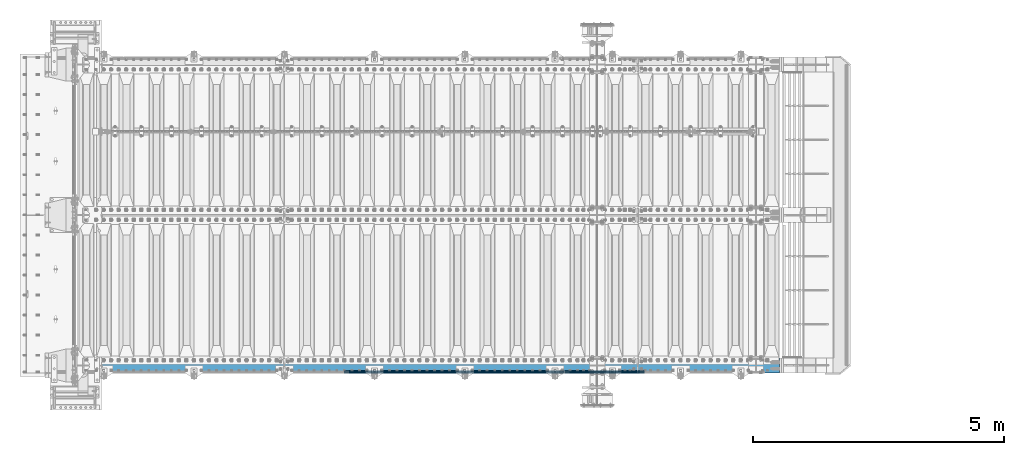
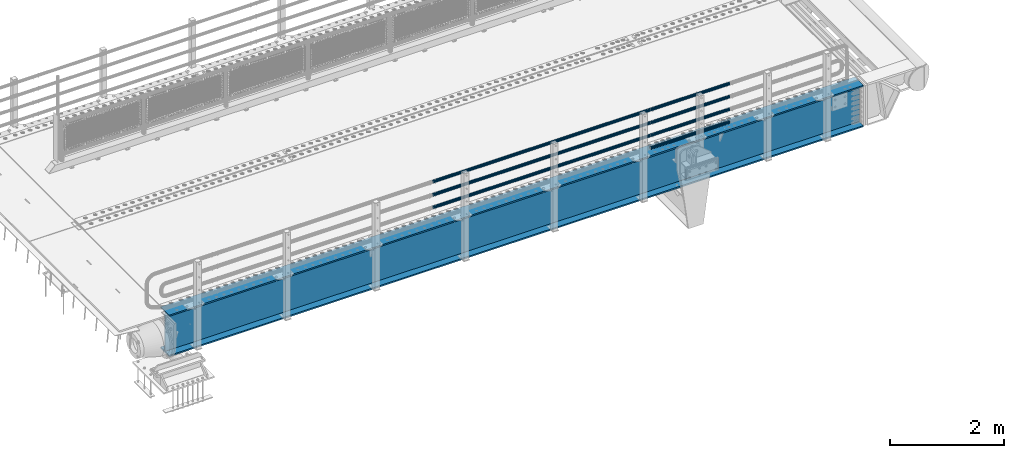
# One storey, part 93 of 193: 8 beams.
"""IFC2X3 building model written with IfcOpenShell, lengths in millimetres."""

from ifc_helpers import new_model, si_unit, frame, origin_with_axes, place, context, subcontext, project, spatial, faceted_brep, material, type_object, element, save


model = new_model("IFC2X3")

# Units and contexts
model_context = context("Model", 3, precision=1e-05, world=origin_with_axes())
body_context = subcontext(model_context, "Body", "Model", "MODEL_VIEW")
ifc_project = project(units=[si_unit("LENGTHUNIT", "METRE", prefix="MILLI"), si_unit("AREAUNIT", "SQUARE_METRE"), si_unit("VOLUMEUNIT", "CUBIC_METRE"), si_unit("MASSUNIT", "GRAM", prefix="KILO"), si_unit("TIMEUNIT", "SECOND"), si_unit("PLANEANGLEUNIT", "RADIAN"), si_unit("SOLIDANGLEUNIT", "STERADIAN"), si_unit("THERMODYNAMICTEMPERATUREUNIT", "DEGREE_CELSIUS"), si_unit("LUMINOUSINTENSITYUNIT", "LUMEN")], contexts=[model_context])

# Site, building, storey
site_placement = place(None, origin_with_axes())
site = spatial("IfcSite", under=ifc_project, at=site_placement, CompositionType="ELEMENT")
building_placement = place(site_placement, origin_with_axes())
building = spatial("IfcBuilding", under=site, at=building_placement, Name="Standard", CompositionType="ELEMENT")
storey_placement = place(building_placement, origin_with_axes())
storey = spatial("IfcBuildingStorey", under=building, at=storey_placement, Name="Undefined", CompositionType="ELEMENT", Elevation=0.0)

# Beams
ifc_material_1 = material()
beam_type_1 = type_object("IfcBeamType", PredefinedType="NOTDEFINED")
beam_1_placement = place(storey_placement, frame((-31118.0000000001, 23870.1500000002, 149.849999999748), z_axis=(0.0, 0.0, -1.0), x_axis=(-1.0, 0.0, 0.0)))
element("IfcBeam", 1, at=beam_1_placement, inside=storey, type_object=beam_type_1, material=ifc_material_1, context=body_context, shape_type="Brep", body=[
    faceted_brep([(0.0, -26.5499999999993, 0.0), (0.0, -24.5290015881765, 10.1602451292931), (1594.0, -24.5290015881765, 10.1602451292931), (1594.0, -26.5499999999993, 0.0), (0.0, -18.7736850405017, 18.7736850405028), (1594.0, -18.7736850405017, 18.7736850405028), (0.0, -10.1602451292929, 24.5290015881747), (1594.0, -10.1602451292929, 24.5290015881747), (0.0, 0.0, 26.55), (1594.0, 0.0, 26.55), (0.0, 10.1602451292929, 24.5290015881747), (1594.0, 10.1602451292929, 24.5290015881747), (0.0, 18.7736850405017, 18.7736850405028), (1594.0, 18.7736850405017, 18.7736850405028), (0.0, 24.5290015881765, 10.1602451292931), (1594.0, 24.5290015881765, 10.1602451292931), (0.0, 26.5499999999993, 0.0), (1594.0, 26.5499999999993, 0.0), (0.0, 24.5290015881765, -10.1602451292931), (1594.0, 24.5290015881765, -10.1602451292931), (0.0, 18.7736850405017, -18.7736850405028), (1594.0, 18.7736850405017, -18.7736850405028), (0.0, 10.1602451292929, -24.5290015881747), (1594.0, 10.1602451292929, -24.5290015881747), (0.0, 0.0, -26.55), (1594.0, 0.0, -26.55), (0.0, -10.1602451292929, -24.5290015881747), (1594.0, -10.1602451292929, -24.5290015881747), (0.0, -18.7736850405017, -18.7736850405028), (1594.0, -18.7736850405017, -18.7736850405028), (0.0, -24.5290015881765, -10.1602451292931), (1594.0, -24.5290015881765, -10.1602451292931), (0.0, -30.1500000000015, 0.0), (0.0, -27.8549679052157, -11.5379054858058), (1594.0, -27.8549679052157, -11.5379054858075), (1594.0, -30.1500000000015, 0.0), (0.0, -21.3192694527752, -21.3192694527752), (1594.0, -21.3192694527752, -21.3192694527744), (0.0, -11.5379054858058, -27.8549679052157), (1594.0, -11.5379054858058, -27.8549679052153), (0.0, 0.0, -30.1500000000015), (1594.0, 0.0, -30.15), (0.0, 11.5379054858058, -27.8549679052157), (1594.0, 11.5379054858058, -27.8549679052153), (0.0, 21.3192694527752, -21.3192694527752), (1594.0, 21.3192694527752, -21.3192694527744), (0.0, 27.8549679052157, -11.5379054858058), (1594.0, 27.8549679052157, -11.5379054858074), (0.0, 30.1500000000015, 0.0), (1594.0, 30.1500000000015, 0.0), (0.0, 27.8549679052157, 11.5379054858058), (1594.0, 27.8549679052157, 11.5379054858075), (0.0, 21.3192694527752, 21.3192694527752), (1594.0, 21.3192694527752, 21.3192694527744), (0.0, 11.5379054858058, 27.8549679052157), (1594.0, 11.5379054858058, 27.8549679052153), (0.0, 0.0, 30.1500000000015), (1594.0, 0.0, 30.15), (0.0, -11.5379054858058, 27.8549679052157), (1594.0, -11.5379054858058, 27.8549679052153), (0.0, -21.3192694527752, 21.3192694527752), (1594.0, -21.3192694527752, 21.3192694527744), (0.0, -27.8549679052157, 11.5379054858058), (1594.0, -27.8549679052157, 11.5379054858075)], [[[0, 1, 2, 3]], [[1, 4, 5, 2]], [[4, 6, 7, 5]], [[6, 8, 9, 7]], [[8, 10, 11, 9]], [[10, 12, 13, 11]], [[12, 14, 15, 13]], [[14, 16, 17, 15]], [[16, 18, 19, 17]], [[18, 20, 21, 19]], [[20, 22, 23, 21]], [[22, 24, 25, 23]], [[24, 26, 27, 25]], [[26, 28, 29, 27]], [[28, 30, 31, 29]], [[30, 0, 3, 31]], [[32, 33, 34, 35]], [[33, 36, 37, 34]], [[36, 38, 39, 37]], [[38, 40, 41, 39]], [[40, 42, 43, 41]], [[42, 44, 45, 43]], [[44, 46, 47, 45]], [[46, 48, 49, 47]], [[48, 50, 51, 49]], [[50, 52, 53, 51]], [[52, 54, 55, 53]], [[54, 56, 57, 55]], [[56, 58, 59, 57]], [[58, 60, 61, 59]], [[60, 62, 63, 61]], [[62, 32, 35, 63]], [[37, 39, 41, 43, 45, 47, 49, 51, 53, 55, 57, 59, 61, 63, 35, 34], [5, 7, 9, 11, 13, 15, 17, 19, 21, 23, 25, 27, 29, 31, 3, 2]], [[62, 60, 58, 56, 54, 52, 50, 48, 46, 44, 42, 40, 38, 36, 33, 32], [30, 28, 26, 24, 22, 20, 18, 16, 14, 12, 10, 8, 6, 4, 1, 0]]]),
])
beam_2_placement = place(storey_placement, frame((-32722.0000000001, 23870.1500000001, 420.149999999748), z_axis=(0.0, 0.0, -1.0), x_axis=(-1.0, 0.0, 0.0)))
element("IfcBeam", 2, at=beam_2_placement, inside=storey, type_object=beam_type_1, material=ifc_material_1, context=body_context, shape_type="Brep", body=[
    faceted_brep([(0.0, -26.5499999999993, 0.0), (0.0, -24.5290015881765, 10.1602451292931), (4384.00249699992, -24.5290015881765, 10.1602451292931), (4384.00249699992, -26.5499999999993, 0.0), (0.0, -18.7736850405017, 18.7736850405028), (4384.00249699992, -18.7736850405017, 18.7736850405028), (0.0, -10.1602451292929, 24.5290015881747), (4384.00249699992, -10.1602451292929, 24.5290015881747), (0.0, 0.0, 26.55), (4384.00249699992, 0.0, 26.55), (0.0, 10.1602451292929, 24.5290015881747), (4384.00249699992, 10.1602451292929, 24.5290015881747), (0.0, 18.7736850405017, 18.7736850405028), (4384.00249699992, 18.7736850405017, 18.7736850405028), (0.0, 24.5290015881765, 10.1602451292931), (4384.00249699992, 24.5290015881765, 10.1602451292931), (0.0, 26.5499999999993, 0.0), (4384.00249699992, 26.5499999999993, 0.0), (0.0, 24.5290015881765, -10.1602451292931), (4384.00249699992, 24.5290015881765, -10.1602451292931), (0.0, 18.7736850405017, -18.7736850405028), (4384.00249699992, 18.7736850405017, -18.7736850405028), (0.0, 10.1602451292929, -24.5290015881747), (4384.00249699992, 10.1602451292929, -24.5290015881747), (0.0, 0.0, -26.55), (4384.00249699992, 0.0, -26.55), (0.0, -10.1602451292929, -24.5290015881747), (4384.00249699992, -10.1602451292929, -24.5290015881747), (0.0, -18.7736850405017, -18.7736850405028), (4384.00249699992, -18.7736850405017, -18.7736850405028), (0.0, -24.5290015881765, -10.1602451292931), (4384.00249699992, -24.5290015881765, -10.1602451292931), (0.0, -30.1500000000015, 0.0), (0.0, -27.8549679052157, -11.5379054858058), (4384.00249699992, -27.8549679052157, -11.5379054858075), (4384.00249699992, -30.1500000000015, 0.0), (0.0, -21.3192694527752, -21.3192694527752), (4384.00249699992, -21.3192694527752, -21.3192694527744), (0.0, -11.5379054858058, -27.8549679052157), (4384.00249699992, -11.5379054858058, -27.8549679052153), (0.0, 0.0, -30.1500000000015), (4384.00249699992, 0.0, -30.15), (0.0, 11.5379054858058, -27.8549679052157), (4384.00249699992, 11.5379054858058, -27.8549679052153), (0.0, 21.3192694527752, -21.3192694527752), (4384.00249699992, 21.3192694527752, -21.3192694527744), (0.0, 27.8549679052157, -11.5379054858058), (4384.00249699992, 27.8549679052157, -11.5379054858074), (0.0, 30.1500000000015, 0.0), (4384.00249699992, 30.1500000000015, 0.0), (0.0, 27.8549679052157, 11.5379054858058), (4384.00249699992, 27.8549679052157, 11.5379054858075), (0.0, 21.3192694527752, 21.3192694527752), (4384.00249699992, 21.3192694527752, 21.3192694527744), (0.0, 11.5379054858058, 27.8549679052157), (4384.00249699992, 11.5379054858058, 27.8549679052153), (0.0, 0.0, 30.1500000000015), (4384.00249699992, 0.0, 30.15), (0.0, -11.5379054858058, 27.8549679052157), (4384.00249699992, -11.5379054858058, 27.8549679052153), (0.0, -21.3192694527752, 21.3192694527752), (4384.00249699992, -21.3192694527752, 21.3192694527744), (0.0, -27.8549679052157, 11.5379054858058), (4384.00249699992, -27.8549679052157, 11.5379054858075)], [[[0, 1, 2, 3]], [[1, 4, 5, 2]], [[4, 6, 7, 5]], [[6, 8, 9, 7]], [[8, 10, 11, 9]], [[10, 12, 13, 11]], [[12, 14, 15, 13]], [[14, 16, 17, 15]], [[16, 18, 19, 17]], [[18, 20, 21, 19]], [[20, 22, 23, 21]], [[22, 24, 25, 23]], [[24, 26, 27, 25]], [[26, 28, 29, 27]], [[28, 30, 31, 29]], [[30, 0, 3, 31]], [[32, 33, 34, 35]], [[33, 36, 37, 34]], [[36, 38, 39, 37]], [[38, 40, 41, 39]], [[40, 42, 43, 41]], [[42, 44, 45, 43]], [[44, 46, 47, 45]], [[46, 48, 49, 47]], [[48, 50, 51, 49]], [[50, 52, 53, 51]], [[52, 54, 55, 53]], [[54, 56, 57, 55]], [[56, 58, 59, 57]], [[58, 60, 61, 59]], [[60, 62, 63, 61]], [[62, 32, 35, 63]], [[37, 39, 41, 43, 45, 47, 49, 51, 53, 55, 57, 59, 61, 63, 35, 34], [5, 7, 9, 11, 13, 15, 17, 19, 21, 23, 25, 27, 29, 31, 3, 2]], [[62, 60, 58, 56, 54, 52, 50, 48, 46, 44, 42, 40, 38, 36, 33, 32], [30, 28, 26, 24, 22, 20, 18, 16, 14, 12, 10, 8, 6, 4, 1, 0]]]),
])
beam_3_placement = place(storey_placement, frame((-31118.0000000001, 23870.1500000002, 420.149999999748), z_axis=(0.0, 0.0, -1.0), x_axis=(-1.0, 0.0, 0.0)))
element("IfcBeam", 3, at=beam_3_placement, inside=storey, type_object=beam_type_1, material=ifc_material_1, context=body_context, shape_type="Brep", body=[
    faceted_brep([(0.0, -26.5499999999993, 0.0), (0.0, -24.5290015881765, 10.1602451292931), (1594.0, -24.5290015881765, 10.1602451292931), (1594.0, -26.5499999999993, 0.0), (0.0, -18.7736850405017, 18.7736850405028), (1594.0, -18.7736850405017, 18.7736850405028), (0.0, -10.1602451292929, 24.5290015881747), (1594.0, -10.1602451292929, 24.5290015881747), (0.0, 0.0, 26.55), (1594.0, 0.0, 26.55), (0.0, 10.1602451292929, 24.5290015881747), (1594.0, 10.1602451292929, 24.5290015881747), (0.0, 18.7736850405017, 18.7736850405028), (1594.0, 18.7736850405017, 18.7736850405028), (0.0, 24.5290015881765, 10.1602451292931), (1594.0, 24.5290015881765, 10.1602451292931), (0.0, 26.5499999999993, 0.0), (1594.0, 26.5499999999993, 0.0), (0.0, 24.5290015881765, -10.1602451292931), (1594.0, 24.5290015881765, -10.1602451292931), (0.0, 18.7736850405017, -18.7736850405028), (1594.0, 18.7736850405017, -18.7736850405028), (0.0, 10.1602451292929, -24.5290015881747), (1594.0, 10.1602451292929, -24.5290015881747), (0.0, 0.0, -26.55), (1594.0, 0.0, -26.55), (0.0, -10.1602451292929, -24.5290015881747), (1594.0, -10.1602451292929, -24.5290015881747), (0.0, -18.7736850405017, -18.7736850405028), (1594.0, -18.7736850405017, -18.7736850405028), (0.0, -24.5290015881765, -10.1602451292931), (1594.0, -24.5290015881765, -10.1602451292931), (0.0, -30.1500000000015, 0.0), (0.0, -27.8549679052157, -11.5379054858058), (1594.0, -27.8549679052157, -11.5379054858075), (1594.0, -30.1500000000015, 0.0), (0.0, -21.3192694527752, -21.3192694527752), (1594.0, -21.3192694527752, -21.3192694527744), (0.0, -11.5379054858058, -27.8549679052157), (1594.0, -11.5379054858058, -27.8549679052153), (0.0, 0.0, -30.1500000000015), (1594.0, 0.0, -30.15), (0.0, 11.5379054858058, -27.8549679052157), (1594.0, 11.5379054858058, -27.8549679052153), (0.0, 21.3192694527752, -21.3192694527752), (1594.0, 21.3192694527752, -21.3192694527744), (0.0, 27.8549679052157, -11.5379054858058), (1594.0, 27.8549679052157, -11.5379054858074), (0.0, 30.1500000000015, 0.0), (1594.0, 30.1500000000015, 0.0), (0.0, 27.8549679052157, 11.5379054858058), (1594.0, 27.8549679052157, 11.5379054858075), (0.0, 21.3192694527752, 21.3192694527752), (1594.0, 21.3192694527752, 21.3192694527744), (0.0, 11.5379054858058, 27.8549679052157), (1594.0, 11.5379054858058, 27.8549679052153), (0.0, 0.0, 30.1500000000015), (1594.0, 0.0, 30.15), (0.0, -11.5379054858058, 27.8549679052157), (1594.0, -11.5379054858058, 27.8549679052153), (0.0, -21.3192694527752, 21.3192694527752), (1594.0, -21.3192694527752, 21.3192694527744), (0.0, -27.8549679052157, 11.5379054858058), (1594.0, -27.8549679052157, 11.5379054858075)], [[[0, 1, 2, 3]], [[1, 4, 5, 2]], [[4, 6, 7, 5]], [[6, 8, 9, 7]], [[8, 10, 11, 9]], [[10, 12, 13, 11]], [[12, 14, 15, 13]], [[14, 16, 17, 15]], [[16, 18, 19, 17]], [[18, 20, 21, 19]], [[20, 22, 23, 21]], [[22, 24, 25, 23]], [[24, 26, 27, 25]], [[26, 28, 29, 27]], [[28, 30, 31, 29]], [[30, 0, 3, 31]], [[32, 33, 34, 35]], [[33, 36, 37, 34]], [[36, 38, 39, 37]], [[38, 40, 41, 39]], [[40, 42, 43, 41]], [[42, 44, 45, 43]], [[44, 46, 47, 45]], [[46, 48, 49, 47]], [[48, 50, 51, 49]], [[50, 52, 53, 51]], [[52, 54, 55, 53]], [[54, 56, 57, 55]], [[56, 58, 59, 57]], [[58, 60, 61, 59]], [[60, 62, 63, 61]], [[62, 32, 35, 63]], [[37, 39, 41, 43, 45, 47, 49, 51, 53, 55, 57, 59, 61, 63, 35, 34], [5, 7, 9, 11, 13, 15, 17, 19, 21, 23, 25, 27, 29, 31, 3, 2]], [[62, 60, 58, 56, 54, 52, 50, 48, 46, 44, 42, 40, 38, 36, 33, 32], [30, 28, 26, 24, 22, 20, 18, 16, 14, 12, 10, 8, 6, 4, 1, 0]]]),
])
beam_4_placement = place(storey_placement, frame((-32722.0000000001, 23870.1500000001, 969.849999999748), z_axis=(0.0, 0.0, -1.0), x_axis=(-1.0, 0.0, 0.0)))
element("IfcBeam", 4, at=beam_4_placement, inside=storey, type_object=beam_type_1, material=ifc_material_1, context=body_context, shape_type="Brep", body=[
    faceted_brep([(0.0, -26.5499999999993, 0.0), (0.0, -24.5290015881765, 10.1602451292931), (4384.00249699992, -24.5290015881765, 10.1602451292931), (4384.00249699992, -26.5499999999993, 0.0), (0.0, -18.7736850405017, 18.7736850405028), (4384.00249699992, -18.7736850405017, 18.7736850405028), (0.0, -10.1602451292929, 24.5290015881747), (4384.00249699992, -10.1602451292929, 24.5290015881747), (0.0, 0.0, 26.55), (4384.00249699992, 0.0, 26.55), (0.0, 10.1602451292929, 24.5290015881747), (4384.00249699992, 10.1602451292929, 24.5290015881747), (0.0, 18.7736850405017, 18.7736850405028), (4384.00249699992, 18.7736850405017, 18.7736850405028), (0.0, 24.5290015881765, 10.1602451292931), (4384.00249699992, 24.5290015881765, 10.1602451292931), (0.0, 26.5499999999993, 0.0), (4384.00249699992, 26.5499999999993, 0.0), (0.0, 24.5290015881765, -10.1602451292931), (4384.00249699992, 24.5290015881765, -10.1602451292931), (0.0, 18.7736850405017, -18.7736850405028), (4384.00249699992, 18.7736850405017, -18.7736850405028), (0.0, 10.1602451292929, -24.5290015881747), (4384.00249699992, 10.1602451292929, -24.5290015881747), (0.0, 0.0, -26.55), (4384.00249699992, 0.0, -26.55), (0.0, -10.1602451292929, -24.5290015881747), (4384.00249699992, -10.1602451292929, -24.5290015881747), (0.0, -18.7736850405017, -18.7736850405028), (4384.00249699992, -18.7736850405017, -18.7736850405028), (0.0, -24.5290015881765, -10.1602451292931), (4384.00249699992, -24.5290015881765, -10.1602451292931), (0.0, -30.1500000000015, 0.0), (0.0, -27.8549679052157, -11.5379054858058), (4384.00249699992, -27.8549679052157, -11.5379054858075), (4384.00249699992, -30.1500000000015, 0.0), (0.0, -21.3192694527752, -21.3192694527752), (4384.00249699992, -21.3192694527752, -21.3192694527744), (0.0, -11.5379054858058, -27.8549679052157), (4384.00249699992, -11.5379054858058, -27.8549679052153), (0.0, 0.0, -30.1500000000015), (4384.00249699992, 0.0, -30.15), (0.0, 11.5379054858058, -27.8549679052157), (4384.00249699992, 11.5379054858058, -27.8549679052153), (0.0, 21.3192694527752, -21.3192694527752), (4384.00249699992, 21.3192694527752, -21.3192694527744), (0.0, 27.8549679052157, -11.5379054858058), (4384.00249699992, 27.8549679052157, -11.5379054858074), (0.0, 30.1500000000015, 0.0), (4384.00249699992, 30.1500000000015, 0.0), (0.0, 27.8549679052157, 11.5379054858058), (4384.00249699992, 27.8549679052157, 11.5379054858075), (0.0, 21.3192694527752, 21.3192694527752), (4384.00249699992, 21.3192694527752, 21.3192694527744), (0.0, 11.5379054858058, 27.8549679052157), (4384.00249699992, 11.5379054858058, 27.8549679052153), (0.0, 0.0, 30.1500000000015), (4384.00249699992, 0.0, 30.15), (0.0, -11.5379054858058, 27.8549679052157), (4384.00249699992, -11.5379054858058, 27.8549679052153), (0.0, -21.3192694527752, 21.3192694527752), (4384.00249699992, -21.3192694527752, 21.3192694527744), (0.0, -27.8549679052157, 11.5379054858058), (4384.00249699992, -27.8549679052157, 11.5379054858075)], [[[0, 1, 2, 3]], [[1, 4, 5, 2]], [[4, 6, 7, 5]], [[6, 8, 9, 7]], [[8, 10, 11, 9]], [[10, 12, 13, 11]], [[12, 14, 15, 13]], [[14, 16, 17, 15]], [[16, 18, 19, 17]], [[18, 20, 21, 19]], [[20, 22, 23, 21]], [[22, 24, 25, 23]], [[24, 26, 27, 25]], [[26, 28, 29, 27]], [[28, 30, 31, 29]], [[30, 0, 3, 31]], [[32, 33, 34, 35]], [[33, 36, 37, 34]], [[36, 38, 39, 37]], [[38, 40, 41, 39]], [[40, 42, 43, 41]], [[42, 44, 45, 43]], [[44, 46, 47, 45]], [[46, 48, 49, 47]], [[48, 50, 51, 49]], [[50, 52, 53, 51]], [[52, 54, 55, 53]], [[54, 56, 57, 55]], [[56, 58, 59, 57]], [[58, 60, 61, 59]], [[60, 62, 63, 61]], [[62, 32, 35, 63]], [[37, 39, 41, 43, 45, 47, 49, 51, 53, 55, 57, 59, 61, 63, 35, 34], [5, 7, 9, 11, 13, 15, 17, 19, 21, 23, 25, 27, 29, 31, 3, 2]], [[62, 60, 58, 56, 54, 52, 50, 48, 46, 44, 42, 40, 38, 36, 33, 32], [30, 28, 26, 24, 22, 20, 18, 16, 14, 12, 10, 8, 6, 4, 1, 0]]]),
])
beam_5_placement = place(storey_placement, frame((-31118.0000000001, 23870.1500000002, 969.849999999748), z_axis=(0.0, 0.0, -1.0), x_axis=(-1.0, 0.0, 0.0)))
element("IfcBeam", 5, at=beam_5_placement, inside=storey, type_object=beam_type_1, material=ifc_material_1, context=body_context, shape_type="Brep", body=[
    faceted_brep([(0.0, -26.5499999999993, 0.0), (0.0, -24.5290015881765, 10.1602451292931), (1594.0, -24.5290015881765, 10.1602451292931), (1594.0, -26.5499999999993, 0.0), (0.0, -18.7736850405017, 18.7736850405028), (1594.0, -18.7736850405017, 18.7736850405028), (0.0, -10.1602451292929, 24.5290015881747), (1594.0, -10.1602451292929, 24.5290015881747), (0.0, 0.0, 26.55), (1594.0, 0.0, 26.55), (0.0, 10.1602451292929, 24.5290015881747), (1594.0, 10.1602451292929, 24.5290015881747), (0.0, 18.7736850405017, 18.7736850405028), (1594.0, 18.7736850405017, 18.7736850405028), (0.0, 24.5290015881765, 10.1602451292931), (1594.0, 24.5290015881765, 10.1602451292931), (0.0, 26.5499999999993, 0.0), (1594.0, 26.5499999999993, 0.0), (0.0, 24.5290015881765, -10.1602451292931), (1594.0, 24.5290015881765, -10.1602451292931), (0.0, 18.7736850405017, -18.7736850405028), (1594.0, 18.7736850405017, -18.7736850405028), (0.0, 10.1602451292929, -24.5290015881747), (1594.0, 10.1602451292929, -24.5290015881747), (0.0, 0.0, -26.55), (1594.0, 0.0, -26.55), (0.0, -10.1602451292929, -24.5290015881747), (1594.0, -10.1602451292929, -24.5290015881747), (0.0, -18.7736850405017, -18.7736850405028), (1594.0, -18.7736850405017, -18.7736850405028), (0.0, -24.5290015881765, -10.1602451292931), (1594.0, -24.5290015881765, -10.1602451292931), (0.0, -30.1500000000015, 0.0), (0.0, -27.8549679052157, -11.5379054858058), (1594.0, -27.8549679052157, -11.5379054858075), (1594.0, -30.1500000000015, 0.0), (0.0, -21.3192694527752, -21.3192694527752), (1594.0, -21.3192694527752, -21.3192694527744), (0.0, -11.5379054858058, -27.8549679052157), (1594.0, -11.5379054858058, -27.8549679052153), (0.0, 0.0, -30.1500000000015), (1594.0, 0.0, -30.15), (0.0, 11.5379054858058, -27.8549679052157), (1594.0, 11.5379054858058, -27.8549679052153), (0.0, 21.3192694527752, -21.3192694527752), (1594.0, 21.3192694527752, -21.3192694527744), (0.0, 27.8549679052157, -11.5379054858058), (1594.0, 27.8549679052157, -11.5379054858074), (0.0, 30.1500000000015, 0.0), (1594.0, 30.1500000000015, 0.0), (0.0, 27.8549679052157, 11.5379054858058), (1594.0, 27.8549679052157, 11.5379054858075), (0.0, 21.3192694527752, 21.3192694527752), (1594.0, 21.3192694527752, 21.3192694527744), (0.0, 11.5379054858058, 27.8549679052157), (1594.0, 11.5379054858058, 27.8549679052153), (0.0, 0.0, 30.1500000000015), (1594.0, 0.0, 30.15), (0.0, -11.5379054858058, 27.8549679052157), (1594.0, -11.5379054858058, 27.8549679052153), (0.0, -21.3192694527752, 21.3192694527752), (1594.0, -21.3192694527752, 21.3192694527744), (0.0, -27.8549679052157, 11.5379054858058), (1594.0, -27.8549679052157, 11.5379054858075)], [[[0, 1, 2, 3]], [[1, 4, 5, 2]], [[4, 6, 7, 5]], [[6, 8, 9, 7]], [[8, 10, 11, 9]], [[10, 12, 13, 11]], [[12, 14, 15, 13]], [[14, 16, 17, 15]], [[16, 18, 19, 17]], [[18, 20, 21, 19]], [[20, 22, 23, 21]], [[22, 24, 25, 23]], [[24, 26, 27, 25]], [[26, 28, 29, 27]], [[28, 30, 31, 29]], [[30, 0, 3, 31]], [[32, 33, 34, 35]], [[33, 36, 37, 34]], [[36, 38, 39, 37]], [[38, 40, 41, 39]], [[40, 42, 43, 41]], [[42, 44, 45, 43]], [[44, 46, 47, 45]], [[46, 48, 49, 47]], [[48, 50, 51, 49]], [[50, 52, 53, 51]], [[52, 54, 55, 53]], [[54, 56, 57, 55]], [[56, 58, 59, 57]], [[58, 60, 61, 59]], [[60, 62, 63, 61]], [[62, 32, 35, 63]], [[37, 39, 41, 43, 45, 47, 49, 51, 53, 55, 57, 59, 61, 63, 35, 34], [5, 7, 9, 11, 13, 15, 17, 19, 21, 23, 25, 27, 29, 31, 3, 2]], [[62, 60, 58, 56, 54, 52, 50, 48, 46, 44, 42, 40, 38, 36, 33, 32], [30, 28, 26, 24, 22, 20, 18, 16, 14, 12, 10, 8, 6, 4, 1, 0]]]),
])
beam_6_placement = place(storey_placement, frame((-32722.0000000001, 23870.1500000001, 689.849999999748), z_axis=(0.0, 0.0, -1.0), x_axis=(-1.0, 0.0, 0.0)))
element("IfcBeam", 6, at=beam_6_placement, inside=storey, type_object=beam_type_1, material=ifc_material_1, context=body_context, shape_type="Brep", body=[
    faceted_brep([(0.0, -26.5499999999993, 0.0), (0.0, -24.5290015881765, 10.1602451292931), (4384.00249699992, -24.5290015881765, 10.1602451292931), (4384.00249699992, -26.5499999999993, 0.0), (0.0, -18.7736850405017, 18.7736850405028), (4384.00249699992, -18.7736850405017, 18.7736850405028), (0.0, -10.1602451292929, 24.5290015881747), (4384.00249699992, -10.1602451292929, 24.5290015881747), (0.0, 0.0, 26.55), (4384.00249699992, 0.0, 26.55), (0.0, 10.1602451292929, 24.5290015881747), (4384.00249699992, 10.1602451292929, 24.5290015881747), (0.0, 18.7736850405017, 18.7736850405028), (4384.00249699992, 18.7736850405017, 18.7736850405028), (0.0, 24.5290015881765, 10.1602451292931), (4384.00249699992, 24.5290015881765, 10.1602451292931), (0.0, 26.5499999999993, 0.0), (4384.00249699992, 26.5499999999993, 0.0), (0.0, 24.5290015881765, -10.1602451292931), (4384.00249699992, 24.5290015881765, -10.1602451292931), (0.0, 18.7736850405017, -18.7736850405028), (4384.00249699992, 18.7736850405017, -18.7736850405028), (0.0, 10.1602451292929, -24.5290015881747), (4384.00249699992, 10.1602451292929, -24.5290015881747), (0.0, 0.0, -26.55), (4384.00249699992, 0.0, -26.55), (0.0, -10.1602451292929, -24.5290015881747), (4384.00249699992, -10.1602451292929, -24.5290015881747), (0.0, -18.7736850405017, -18.7736850405028), (4384.00249699992, -18.7736850405017, -18.7736850405028), (0.0, -24.5290015881765, -10.1602451292931), (4384.00249699992, -24.5290015881765, -10.1602451292931), (0.0, -30.1500000000015, 0.0), (0.0, -27.8549679052157, -11.5379054858058), (4384.00249699992, -27.8549679052157, -11.5379054858075), (4384.00249699992, -30.1500000000015, 0.0), (0.0, -21.3192694527752, -21.3192694527752), (4384.00249699992, -21.3192694527752, -21.3192694527744), (0.0, -11.5379054858058, -27.8549679052157), (4384.00249699992, -11.5379054858058, -27.8549679052153), (0.0, 0.0, -30.1500000000015), (4384.00249699992, 0.0, -30.15), (0.0, 11.5379054858058, -27.8549679052157), (4384.00249699992, 11.5379054858058, -27.8549679052153), (0.0, 21.3192694527752, -21.3192694527752), (4384.00249699992, 21.3192694527752, -21.3192694527744), (0.0, 27.8549679052157, -11.5379054858058), (4384.00249699992, 27.8549679052157, -11.5379054858074), (0.0, 30.1500000000015, 0.0), (4384.00249699992, 30.1500000000015, 0.0), (0.0, 27.8549679052157, 11.5379054858058), (4384.00249699992, 27.8549679052157, 11.5379054858075), (0.0, 21.3192694527752, 21.3192694527752), (4384.00249699992, 21.3192694527752, 21.3192694527744), (0.0, 11.5379054858058, 27.8549679052157), (4384.00249699992, 11.5379054858058, 27.8549679052153), (0.0, 0.0, 30.1500000000015), (4384.00249699992, 0.0, 30.15), (0.0, -11.5379054858058, 27.8549679052157), (4384.00249699992, -11.5379054858058, 27.8549679052153), (0.0, -21.3192694527752, 21.3192694527752), (4384.00249699992, -21.3192694527752, 21.3192694527744), (0.0, -27.8549679052157, 11.5379054858058), (4384.00249699992, -27.8549679052157, 11.5379054858075)], [[[0, 1, 2, 3]], [[1, 4, 5, 2]], [[4, 6, 7, 5]], [[6, 8, 9, 7]], [[8, 10, 11, 9]], [[10, 12, 13, 11]], [[12, 14, 15, 13]], [[14, 16, 17, 15]], [[16, 18, 19, 17]], [[18, 20, 21, 19]], [[20, 22, 23, 21]], [[22, 24, 25, 23]], [[24, 26, 27, 25]], [[26, 28, 29, 27]], [[28, 30, 31, 29]], [[30, 0, 3, 31]], [[32, 33, 34, 35]], [[33, 36, 37, 34]], [[36, 38, 39, 37]], [[38, 40, 41, 39]], [[40, 42, 43, 41]], [[42, 44, 45, 43]], [[44, 46, 47, 45]], [[46, 48, 49, 47]], [[48, 50, 51, 49]], [[50, 52, 53, 51]], [[52, 54, 55, 53]], [[54, 56, 57, 55]], [[56, 58, 59, 57]], [[58, 60, 61, 59]], [[60, 62, 63, 61]], [[62, 32, 35, 63]], [[37, 39, 41, 43, 45, 47, 49, 51, 53, 55, 57, 59, 61, 63, 35, 34], [5, 7, 9, 11, 13, 15, 17, 19, 21, 23, 25, 27, 29, 31, 3, 2]], [[62, 60, 58, 56, 54, 52, 50, 48, 46, 44, 42, 40, 38, 36, 33, 32], [30, 28, 26, 24, 22, 20, 18, 16, 14, 12, 10, 8, 6, 4, 1, 0]]]),
])
beam_7_placement = place(storey_placement, frame((-31118.0000000001, 23870.1500000002, 689.849999999748), z_axis=(0.0, 0.0, -1.0), x_axis=(-1.0, 0.0, 0.0)))
element("IfcBeam", 7, at=beam_7_placement, inside=storey, type_object=beam_type_1, material=ifc_material_1, context=body_context, shape_type="Brep", body=[
    faceted_brep([(0.0, -26.5499999999993, 0.0), (0.0, -24.5290015881765, 10.1602451292931), (1594.0, -24.5290015881765, 10.1602451292931), (1594.0, -26.5499999999993, 0.0), (0.0, -18.7736850405017, 18.7736850405028), (1594.0, -18.7736850405017, 18.7736850405028), (0.0, -10.1602451292929, 24.5290015881747), (1594.0, -10.1602451292929, 24.5290015881747), (0.0, 0.0, 26.55), (1594.0, 0.0, 26.55), (0.0, 10.1602451292929, 24.5290015881747), (1594.0, 10.1602451292929, 24.5290015881747), (0.0, 18.7736850405017, 18.7736850405028), (1594.0, 18.7736850405017, 18.7736850405028), (0.0, 24.5290015881765, 10.1602451292931), (1594.0, 24.5290015881765, 10.1602451292931), (0.0, 26.5499999999993, 0.0), (1594.0, 26.5499999999993, 0.0), (0.0, 24.5290015881765, -10.1602451292931), (1594.0, 24.5290015881765, -10.1602451292931), (0.0, 18.7736850405017, -18.7736850405028), (1594.0, 18.7736850405017, -18.7736850405028), (0.0, 10.1602451292929, -24.5290015881747), (1594.0, 10.1602451292929, -24.5290015881747), (0.0, 0.0, -26.55), (1594.0, 0.0, -26.55), (0.0, -10.1602451292929, -24.5290015881747), (1594.0, -10.1602451292929, -24.5290015881747), (0.0, -18.7736850405017, -18.7736850405028), (1594.0, -18.7736850405017, -18.7736850405028), (0.0, -24.5290015881765, -10.1602451292931), (1594.0, -24.5290015881765, -10.1602451292931), (0.0, -30.1500000000015, 0.0), (0.0, -27.8549679052157, -11.5379054858058), (1594.0, -27.8549679052157, -11.5379054858075), (1594.0, -30.1500000000015, 0.0), (0.0, -21.3192694527752, -21.3192694527752), (1594.0, -21.3192694527752, -21.3192694527744), (0.0, -11.5379054858058, -27.8549679052157), (1594.0, -11.5379054858058, -27.8549679052153), (0.0, 0.0, -30.1500000000015), (1594.0, 0.0, -30.15), (0.0, 11.5379054858058, -27.8549679052157), (1594.0, 11.5379054858058, -27.8549679052153), (0.0, 21.3192694527752, -21.3192694527752), (1594.0, 21.3192694527752, -21.3192694527744), (0.0, 27.8549679052157, -11.5379054858058), (1594.0, 27.8549679052157, -11.5379054858074), (0.0, 30.1500000000015, 0.0), (1594.0, 30.1500000000015, 0.0), (0.0, 27.8549679052157, 11.5379054858058), (1594.0, 27.8549679052157, 11.5379054858075), (0.0, 21.3192694527752, 21.3192694527752), (1594.0, 21.3192694527752, 21.3192694527744), (0.0, 11.5379054858058, 27.8549679052157), (1594.0, 11.5379054858058, 27.8549679052153), (0.0, 0.0, 30.1500000000015), (1594.0, 0.0, 30.15), (0.0, -11.5379054858058, 27.8549679052157), (1594.0, -11.5379054858058, 27.8549679052153), (0.0, -21.3192694527752, 21.3192694527752), (1594.0, -21.3192694527752, 21.3192694527744), (0.0, -27.8549679052157, 11.5379054858058), (1594.0, -27.8549679052157, 11.5379054858075)], [[[0, 1, 2, 3]], [[1, 4, 5, 2]], [[4, 6, 7, 5]], [[6, 8, 9, 7]], [[8, 10, 11, 9]], [[10, 12, 13, 11]], [[12, 14, 15, 13]], [[14, 16, 17, 15]], [[16, 18, 19, 17]], [[18, 20, 21, 19]], [[20, 22, 23, 21]], [[22, 24, 25, 23]], [[24, 26, 27, 25]], [[26, 28, 29, 27]], [[28, 30, 31, 29]], [[30, 0, 3, 31]], [[32, 33, 34, 35]], [[33, 36, 37, 34]], [[36, 38, 39, 37]], [[38, 40, 41, 39]], [[40, 42, 43, 41]], [[42, 44, 45, 43]], [[44, 46, 47, 45]], [[46, 48, 49, 47]], [[48, 50, 51, 49]], [[50, 52, 53, 51]], [[52, 54, 55, 53]], [[54, 56, 57, 55]], [[56, 58, 59, 57]], [[58, 60, 61, 59]], [[60, 62, 63, 61]], [[62, 32, 35, 63]], [[37, 39, 41, 43, 45, 47, 49, 51, 53, 55, 57, 59, 61, 63, 35, 34], [5, 7, 9, 11, 13, 15, 17, 19, 21, 23, 25, 27, 29, 31, 3, 2]], [[62, 60, 58, 56, 54, 52, 50, 48, 46, 44, 42, 40, 38, 36, 33, 32], [30, 28, 26, 24, 22, 20, 18, 16, 14, 12, 10, 8, 6, 4, 1, 0]]]),
])
ifc_material_2 = material(Name="STEEL/S355N")
beam_type_2 = type_object("IfcBeamType", Name="HEA900", PredefinedType="NOTDEFINED")
beam_8_placement = place(storey_placement, frame((-42440.0, 24000.0, -445.0), z_axis=(0.0, 0.0, 1.0), x_axis=(1.0, 0.0, 0.0)))
element("IfcBeam", 8, at=beam_8_placement, inside=storey, type_object=beam_type_2, material=ifc_material_2, ObjectType="HEA900", context=body_context, shape_type="Brep", body=[
    faceted_brep([(0.0, 150.0, -445.0), (0.0, 150.0, -415.0), (14017.0, 150.0, -415.0), (14017.0, 150.0, -445.0), (0.0, 8.0, -415.0), (14017.0, 8.0, -415.0), (0.0, 8.0, 415.0), (14017.0, 8.0, 415.0), (0.0, 150.0, 415.0), (14017.0, 150.0, 415.0), (0.0, 150.0, 445.0), (14017.0, 150.0, 445.0), (0.0, -150.0, 445.0), (14017.0, -150.0, 445.0), (0.0, -150.0, 415.0), (14017.0, -150.0, 415.0), (0.0, -8.0, 415.0), (14017.0, -8.0, 415.0), (0.0, -8.0, -415.0), (14017.0, -8.0, -415.0), (0.0, -150.0, -415.0), (14017.0, -150.0, -415.0), (0.0, -150.0, -445.0), (14017.0, -150.0, -445.0)], [[[0, 1, 2, 3]], [[1, 4, 5, 2]], [[4, 6, 7, 5]], [[6, 8, 9, 7]], [[8, 10, 11, 9]], [[10, 12, 13, 11]], [[12, 14, 15, 13]], [[14, 16, 17, 15]], [[16, 18, 19, 17]], [[18, 20, 21, 19]], [[20, 22, 23, 21]], [[22, 0, 3, 23]], [[5, 7, 9, 11, 13, 15, 17, 19, 21, 23, 3, 2]], [[22, 20, 18, 16, 14, 12, 10, 8, 6, 4, 1, 0]]]),
])

save(model, "model.ifc")
